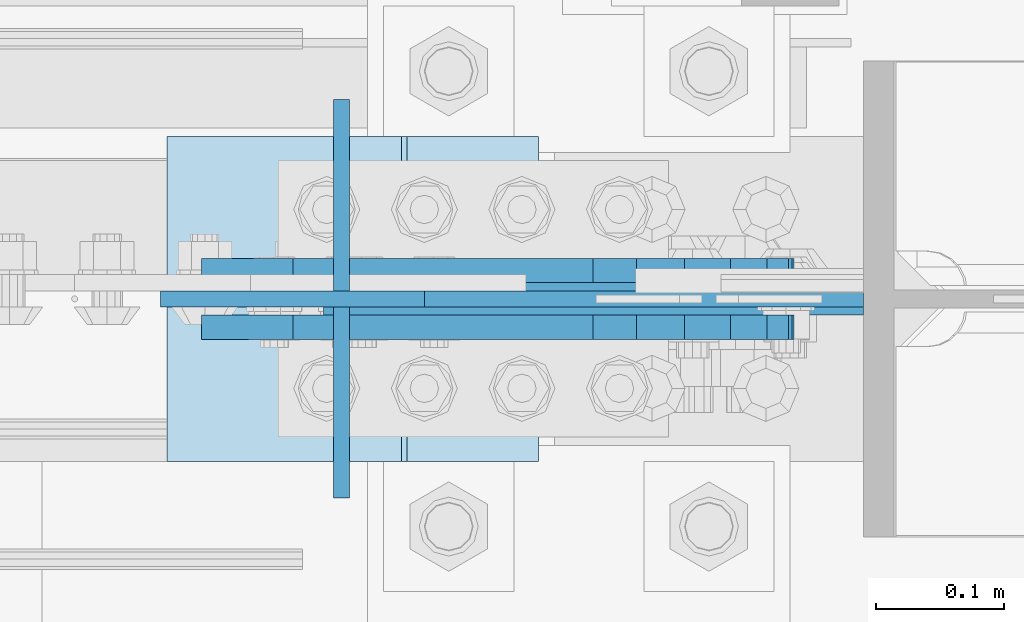
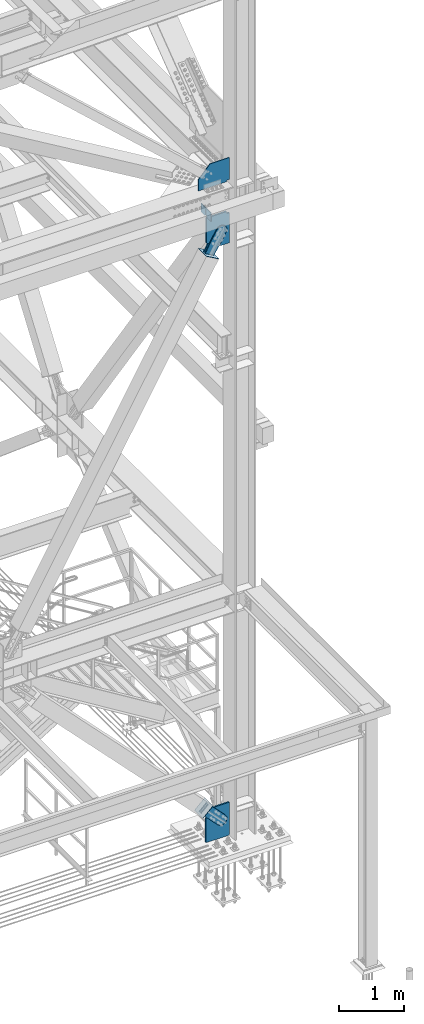
# One storey, part 3560 of 3843: 11 plates, 8 elements without a shape of their own.
"""IFC2X3 building model written with IfcOpenShell, lengths in millimetres."""

from ifc_helpers import new_model, si_unit, frame, origin_with_axes, place, context, subcontext, project, spatial, faceted_brep, material, type_object, element, aggregate, save


model = new_model("IFC2X3")

# Units and contexts
model_context = context("Model", 3, precision=1e-05, world=origin_with_axes())
body_context = subcontext(model_context, "Body", "Model", "MODEL_VIEW")
ifc_project = project(units=[si_unit("LENGTHUNIT", "METRE", prefix="MILLI"), si_unit("AREAUNIT", "SQUARE_METRE"), si_unit("VOLUMEUNIT", "CUBIC_METRE"), si_unit("MASSUNIT", "GRAM", prefix="KILO"), si_unit("TIMEUNIT", "SECOND"), si_unit("PLANEANGLEUNIT", "RADIAN"), si_unit("SOLIDANGLEUNIT", "STERADIAN"), si_unit("THERMODYNAMICTEMPERATUREUNIT", "DEGREE_CELSIUS"), si_unit("LUMINOUSINTENSITYUNIT", "LUMEN")], contexts=[model_context])

# Site, building, storey
site_placement = place(None, origin_with_axes())
site = spatial("IfcSite", under=ifc_project, at=site_placement, CompositionType="ELEMENT")
building_placement = place(site_placement, origin_with_axes())
building = spatial("IfcBuilding", under=site, at=building_placement, Name="Undefined", CompositionType="ELEMENT")
storey_placement = place(building_placement, origin_with_axes())
storey = spatial("IfcBuildingStorey", under=building, at=storey_placement, Name="Undefined", CompositionType="ELEMENT", Elevation=0.0)

# Assembly, plate
assembly_1_placement = place(storey_placement, origin_with_axes())
assembly_1 = element("IfcElementAssembly", 1, at=assembly_1_placement, inside=storey, Name="COLUMN", AssemblyPlace="NOTDEFINED", PredefinedType="RIGID_FRAME")
ifc_material_1 = material(Name="STEEL/A572-50")
plate_type_1 = type_object("IfcPlateType", PredefinedType="NOTDEFINED")
plate_1_placement = place(assembly_1_placement, frame((85464.650000013, 14998.6999998776, 42481.5000000008), z_axis=(0.0, 0.0, 1.0), x_axis=(-1.0, 0.0, 0.0)))
plate_1 = element("IfcPlate", 2, at=plate_1_placement, type_object=plate_type_1, material=ifc_material_1, Name="PLATE", context=body_context, shape_type="Brep", body=[
    faceted_brep([(0.0, -6.35000000000582, 25.3999999992011), (0.0, 6.35000000000582, 25.3999999992011), (38.1000002037326, 6.35000000000582, 25.3999999992011), (38.1000002037326, -6.35000000000582, 25.3999999992011), (42.9600797217718, 6.35000000000582, 24.4332700766099), (42.9600797217718, -6.35000000000582, 24.4332700766099), (47.0802561899327, 6.35000000000582, 21.680256176136), (47.0802561899327, -6.35000000000582, 21.680256176136), (49.8332700904139, 6.35000000000582, 17.5600797079824), (49.8332700904139, -6.35000000000582, 17.5600797079824), (50.8000000129978, -6.35000000000582, 12.700000189936), (50.8000000129978, 6.35000000000582, 12.700000189936), (50.8000000129978, 6.35000000000582, 0.0), (50.8000000129978, -6.35000000000582, 0.0), (0.0, -6.35000000000582, 440.392120302837), (342.865167624404, -6.35000000000582, 440.392120302837), (342.865167624404, 6.35000000000582, 440.392120302837), (0.0, 6.35000000000582, 440.392120302837), (548.874980480497, -6.35000000000582, 215.752415426345), (548.874980480497, 6.35000000000582, 215.752415426345), (548.874980480497, -6.35000000000582, 0.0), (548.874980480497, 6.35000000000582, 0.0)], [[[0, 1, 2, 3]], [[3, 2, 4, 5]], [[5, 4, 6, 7]], [[7, 6, 8, 9]], [[10, 11, 12, 13]], [[9, 8, 11, 10]], [[14, 15, 16, 17]], [[15, 18, 19, 16]], [[18, 20, 21, 19]], [[21, 20, 13, 12]], [[6, 4, 2, 1, 17, 16, 19, 21, 12, 11, 8]], [[14, 17, 1, 0]], [[20, 18, 15, 14, 0, 3, 5, 7, 9, 10, 13]]]),
])

# Assembly, plates
assembly_2_placement = place(storey_placement, origin_with_axes())
assembly_2 = element("IfcElementAssembly", 3, at=assembly_2_placement, inside=storey, Name="BEAM", AssemblyPlace="NOTDEFINED", PredefinedType="RIGID_FRAME")
plate_type_2 = type_object("IfcPlateType", PredefinedType="NOTDEFINED")
plate_2_placement = place(assembly_2_placement, frame((85057.1554852273, 14992.35, 42110.025), z_axis=(0.0, 0.0, -1.0), x_axis=(0.0, -1.0, 0.0)))
plate_2 = element("IfcPlate", 4, at=plate_2_placement, type_object=plate_type_2, material=ifc_material_1, Name="PLATE", context=body_context, shape_type="Brep", body=[
    faceted_brep([(0.0, -6.3499999046162, 0.0), (0.0, -6.35000000000582, 131.762499999997), (0.0, 6.35000000000582, 131.762499999997), (7.27595761418343e-12, 6.3499999046162, 0.0), (31.75, -6.35000000000582, 163.512499999997), (31.75, 6.35000000000582, 163.512499999997), (149.224999999991, -6.35000000000582, 163.512499999997), (149.224999999991, 6.35000000000582, 163.512499999997), (149.224999999991, -6.35000000000582, 0.0), (149.224999999991, 6.35000000000582, 0.0)], [[[0, 1, 2, 3]], [[1, 4, 5, 2]], [[4, 6, 7, 5]], [[6, 8, 9, 7]], [[8, 0, 3, 9]], [[5, 7, 9, 3, 2]], [[8, 6, 4, 1, 0]]]),
])
plate_3_placement = place(assembly_2_placement, frame((85057.1554852273, 15154.275, 42110.025), z_axis=(0.0, 0.0, -1.0), x_axis=(0.0, -1.0, 0.0)))
plate_3 = element("IfcPlate", 5, at=plate_3_placement, type_object=plate_type_2, material=ifc_material_1, Name="PLATE", context=body_context, shape_type="Brep", body=[
    faceted_brep([(0.0, -6.3499999046162, 0.0), (0.0, -6.34999999999854, 163.512499999997), (0.0, 6.34999999999854, 163.512499999997), (7.27595761418343e-12, 6.3499999046162, 0.0), (117.474999999991, -6.34999999999854, 163.512499999997), (117.474999999991, 6.34999999999854, 163.512499999997), (149.224999999991, -6.34999999999854, 131.762499999997), (149.224999999991, 6.34999999999854, 131.762499999997), (149.224999999991, -6.35000000000582, 0.0), (149.224999999991, 6.35000000000582, 0.0)], [[[0, 1, 2, 3]], [[1, 4, 5, 2]], [[4, 6, 7, 5]], [[6, 8, 9, 7]], [[8, 0, 3, 9]], [[5, 7, 9, 3, 2]], [[8, 6, 4, 1, 0]]]),
])
aggregate(assembly_2, [plate_2, plate_3])

# Assembly, plate
assembly_3_placement = place(storey_placement, origin_with_axes())
assembly_3 = element("IfcElementAssembly", 6, at=assembly_3_placement, inside=storey, AssemblyPlace="NOTDEFINED", PredefinedType="RIGID_FRAME")
ifc_material_2 = material(Name="STEEL/A36")
plate_type_3 = type_object("IfcPlateType", PredefinedType="NOTDEFINED")
plate_4_placement = place(assembly_3_placement, frame((85076.9563699565, 15020.925, 30872.9925241429), z_axis=(-0.720244694304652, 0.0, -0.693720102293424), x_axis=(0.693720102293427, 0.0, -0.720244694304649)))
plate_4 = element("IfcPlate", 7, at=plate_4_placement, type_object=plate_type_3, material=ifc_material_2, context=body_context, shape_type="Brep", body=[
    faceted_brep([(0.0, -9.52500000000146, 0.0), (7.37782102078199e-09, -9.52499999999418, 179.651701450231), (7.37782102078199e-09, 9.52499999999418, 179.651701450231), (0.0, 9.52500000000146, 0.0), (69.8500000062704, -9.52499999999418, 179.651701450392), (69.8500000062704, 9.52499999999418, 179.651701450392), (171.449999998309, -9.52499999999418, 186.663350727089), (171.449999998309, 9.52499999999418, 186.663350727089), (434.579297655291, -9.52499999999418, 186.663350728457), (434.579297655291, 9.52499999999418, 186.663350728457), (471.637405120986, -9.52499999999418, 179.292034842016), (471.637405120986, 9.52499999999418, 179.292034842016), (503.05375165752, -9.52499999999418, 158.300303204887), (503.05375165752, 9.52499999999418, 158.300303204887), (524.045483294532, -9.52499999999418, 126.883956668345), (524.045483294532, 9.52499999999418, 126.883956668345), (531.416799180792, -9.52499999999418, 89.8258522538526), (531.416799180792, 9.52499999999418, 89.8258522538526), (524.045483293885, -9.52499999999418, 52.7677447886235), (524.045483293885, 9.52499999999418, 52.7677447886235), (503.053751656611, -9.52499999999418, 21.3513982523873), (503.053751656611, 9.52499999999418, 21.3513982523873), (471.637405120178, -9.52499999999418, 0.359666615346214), (471.637405120178, 9.52499999999418, 0.359666615346214), (434.579299181831, -9.52499999999418, -7.01164927131322), (434.579299181831, 9.52499999999418, -7.01164927131322), (171.449999996272, -9.52499999999418, -7.01164927269565), (171.449999996272, 9.52499999999418, -7.01164927269565), (69.8499999979995, -9.52499999999418, -4.00177668780088e-10), (69.8499999979995, 9.52499999999418, -4.00177668780088e-10)], [[[0, 1, 2, 3]], [[1, 4, 5, 2]], [[4, 6, 7, 5]], [[6, 8, 9, 7]], [[8, 10, 11, 9]], [[10, 12, 13, 11]], [[12, 14, 15, 13]], [[14, 16, 17, 15]], [[16, 18, 19, 17]], [[18, 20, 21, 19]], [[20, 22, 23, 21]], [[22, 24, 25, 23]], [[24, 26, 27, 25]], [[26, 28, 29, 27]], [[28, 0, 3, 29]], [[5, 7, 9, 11, 13, 15, 17, 19, 21, 23, 25, 27, 29, 3, 2]], [[28, 26, 24, 22, 20, 18, 16, 14, 12, 10, 8, 6, 4, 1, 0]]]),
])
aggregate(assembly_3, [plate_4])

assembly_4_placement = place(storey_placement, origin_with_axes())
assembly_4 = element("IfcElementAssembly", 8, at=assembly_4_placement, inside=storey, AssemblyPlace="NOTDEFINED", PredefinedType="RIGID_FRAME")
plate_5_placement = place(assembly_4_placement, frame((85076.9563699565, 14976.475, 30872.9925241429), z_axis=(-0.720244694304652, 0.0, -0.693720102293424), x_axis=(0.693720102293427, 0.0, -0.720244694304649)))
plate_5 = element("IfcPlate", 9, at=plate_5_placement, type_object=plate_type_3, material=ifc_material_2, context=body_context, shape_type="Brep", body=[
    faceted_brep([(0.0, -9.52500000000146, 0.0), (7.37782102078199e-09, -9.52499999999418, 179.651701450231), (7.37782102078199e-09, 9.52499999999418, 179.651701450231), (0.0, 9.52500000000146, 0.0), (69.8500000062704, -9.52499999999418, 179.651701450392), (69.8500000062704, 9.52499999999418, 179.651701450392), (171.449999998309, -9.52499999999418, 186.663350727089), (171.449999998309, 9.52499999999418, 186.663350727089), (434.579297655291, -9.52499999999418, 186.663350728457), (434.579297655291, 9.52499999999418, 186.663350728457), (471.637405120986, -9.52499999999418, 179.292034842016), (471.637405120986, 9.52499999999418, 179.292034842016), (503.05375165752, -9.52499999999418, 158.300303204887), (503.05375165752, 9.52499999999418, 158.300303204887), (524.045483294532, -9.52499999999418, 126.883956668345), (524.045483294532, 9.52499999999418, 126.883956668345), (531.416799180792, -9.52499999999418, 89.8258522538526), (531.416799180792, 9.52499999999418, 89.8258522538526), (524.045483293885, -9.52499999999418, 52.7677447886235), (524.045483293885, 9.52499999999418, 52.7677447886235), (503.053751656611, -9.52499999999418, 21.3513982523873), (503.053751656611, 9.52499999999418, 21.3513982523873), (471.637405120178, -9.52499999999418, 0.359666615346214), (471.637405120178, 9.52499999999418, 0.359666615346214), (434.579299181831, -9.52499999999418, -7.01164927131322), (434.579299181831, 9.52499999999418, -7.01164927131322), (171.449999996272, -9.52499999999418, -7.01164927269565), (171.449999996272, 9.52499999999418, -7.01164927269565), (69.8499999979995, -9.52499999999418, -4.00177668780088e-10), (69.8499999979995, 9.52499999999418, -4.00177668780088e-10)], [[[0, 1, 2, 3]], [[1, 4, 5, 2]], [[4, 6, 7, 5]], [[6, 8, 9, 7]], [[8, 10, 11, 9]], [[10, 12, 13, 11]], [[12, 14, 15, 13]], [[14, 16, 17, 15]], [[16, 18, 19, 17]], [[18, 20, 21, 19]], [[20, 22, 23, 21]], [[22, 24, 25, 23]], [[24, 26, 27, 25]], [[26, 28, 29, 27]], [[28, 0, 3, 29]], [[5, 7, 9, 11, 13, 15, 17, 19, 21, 23, 25, 27, 29, 3, 2]], [[28, 26, 24, 22, 20, 18, 16, 14, 12, 10, 8, 6, 4, 1, 0]]]),
])
aggregate(assembly_4, [plate_5])

assembly_5_placement = place(storey_placement, origin_with_axes())
assembly_5 = element("IfcElementAssembly", 10, at=assembly_5_placement, inside=storey, AssemblyPlace="NOTDEFINED", PredefinedType="RIGID_FRAME")
plate_6_placement = place(assembly_5_placement, frame((85175.3798783938, 15020.925, 41186.7888602026), z_axis=(-0.868467373134178, 0.0, 0.495746328076589), x_axis=(0.495746328076604, 0.0, 0.868467373134169)))
plate_6 = element("IfcPlate", 11, at=plate_6_placement, type_object=plate_type_3, material=ifc_material_2, context=body_context, shape_type="Brep", body=[
    faceted_brep([(0.0, -9.52500000000146, 0.0), (7.37782102078199e-09, -9.52499999999418, 179.651701450231), (7.37782102078199e-09, 9.52499999999418, 179.651701450231), (0.0, 9.52500000000146, 0.0), (69.8500000062704, -9.52499999999418, 179.651701450392), (69.8500000062704, 9.52499999999418, 179.651701450392), (171.449999998309, -9.52499999999418, 186.663350727089), (171.449999998309, 9.52499999999418, 186.663350727089), (434.579297655291, -9.52499999999418, 186.663350728457), (434.579297655291, 9.52499999999418, 186.663350728457), (471.637405120986, -9.52499999999418, 179.292034842016), (471.637405120986, 9.52499999999418, 179.292034842016), (503.05375165752, -9.52499999999418, 158.300303204887), (503.05375165752, 9.52499999999418, 158.300303204887), (524.045483294532, -9.52499999999418, 126.883956668345), (524.045483294532, 9.52499999999418, 126.883956668345), (531.416799180792, -9.52499999999418, 89.8258522538526), (531.416799180792, 9.52499999999418, 89.8258522538526), (524.045483293885, -9.52499999999418, 52.7677447886235), (524.045483293885, 9.52499999999418, 52.7677447886235), (503.053751656611, -9.52499999999418, 21.3513982523873), (503.053751656611, 9.52499999999418, 21.3513982523873), (471.637405120178, -9.52499999999418, 0.359666615346214), (471.637405120178, 9.52499999999418, 0.359666615346214), (434.579299181831, -9.52499999999418, -7.01164927131322), (434.579299181831, 9.52499999999418, -7.01164927131322), (171.449999996272, -9.52499999999418, -7.01164927269565), (171.449999996272, 9.52499999999418, -7.01164927269565), (69.8499999979995, -9.52499999999418, -4.00177668780088e-10), (69.8499999979995, 9.52499999999418, -4.00177668780088e-10)], [[[0, 1, 2, 3]], [[1, 4, 5, 2]], [[4, 6, 7, 5]], [[6, 8, 9, 7]], [[8, 10, 11, 9]], [[10, 12, 13, 11]], [[12, 14, 15, 13]], [[14, 16, 17, 15]], [[16, 18, 19, 17]], [[18, 20, 21, 19]], [[20, 22, 23, 21]], [[22, 24, 25, 23]], [[24, 26, 27, 25]], [[26, 28, 29, 27]], [[28, 0, 3, 29]], [[5, 7, 9, 11, 13, 15, 17, 19, 21, 23, 25, 27, 29, 3, 2]], [[28, 26, 24, 22, 20, 18, 16, 14, 12, 10, 8, 6, 4, 1, 0]]]),
])
aggregate(assembly_5, [plate_6])

assembly_6_placement = place(storey_placement, origin_with_axes())
assembly_6 = element("IfcElementAssembly", 12, at=assembly_6_placement, inside=storey, AssemblyPlace="NOTDEFINED", PredefinedType="RIGID_FRAME")
plate_7_placement = place(assembly_6_placement, frame((85175.3798783938, 14976.475, 41186.7888602026), z_axis=(-0.868467373134178, 0.0, 0.495746328076589), x_axis=(0.495746328076604, 0.0, 0.868467373134169)))
plate_7 = element("IfcPlate", 13, at=plate_7_placement, type_object=plate_type_3, material=ifc_material_2, context=body_context, shape_type="Brep", body=[
    faceted_brep([(0.0, -9.52500000000146, 0.0), (7.37782102078199e-09, -9.52499999999418, 179.651701450231), (7.37782102078199e-09, 9.52499999999418, 179.651701450231), (0.0, 9.52500000000146, 0.0), (69.8500000062704, -9.52499999999418, 179.651701450392), (69.8500000062704, 9.52499999999418, 179.651701450392), (171.449999998309, -9.52499999999418, 186.663350727089), (171.449999998309, 9.52499999999418, 186.663350727089), (434.579297655291, -9.52499999999418, 186.663350728457), (434.579297655291, 9.52499999999418, 186.663350728457), (471.637405120986, -9.52499999999418, 179.292034842016), (471.637405120986, 9.52499999999418, 179.292034842016), (503.05375165752, -9.52499999999418, 158.300303204887), (503.05375165752, 9.52499999999418, 158.300303204887), (524.045483294532, -9.52499999999418, 126.883956668345), (524.045483294532, 9.52499999999418, 126.883956668345), (531.416799180792, -9.52499999999418, 89.8258522538526), (531.416799180792, 9.52499999999418, 89.8258522538526), (524.045483293885, -9.52499999999418, 52.7677447886235), (524.045483293885, 9.52499999999418, 52.7677447886235), (503.053751656611, -9.52499999999418, 21.3513982523873), (503.053751656611, 9.52499999999418, 21.3513982523873), (471.637405120178, -9.52499999999418, 0.359666615346214), (471.637405120178, 9.52499999999418, 0.359666615346214), (434.579299181831, -9.52499999999418, -7.01164927131322), (434.579299181831, 9.52499999999418, -7.01164927131322), (171.449999996272, -9.52499999999418, -7.01164927269565), (171.449999996272, 9.52499999999418, -7.01164927269565), (69.8499999979995, -9.52499999999418, -4.00177668780088e-10), (69.8499999979995, 9.52499999999418, -4.00177668780088e-10)], [[[0, 1, 2, 3]], [[1, 4, 5, 2]], [[4, 6, 7, 5]], [[6, 8, 9, 7]], [[8, 10, 11, 9]], [[10, 12, 13, 11]], [[12, 14, 15, 13]], [[14, 16, 17, 15]], [[16, 18, 19, 17]], [[18, 20, 21, 19]], [[20, 22, 23, 21]], [[22, 24, 25, 23]], [[24, 26, 27, 25]], [[26, 28, 29, 27]], [[28, 0, 3, 29]], [[5, 7, 9, 11, 13, 15, 17, 19, 21, 23, 25, 27, 29, 3, 2]], [[28, 26, 24, 22, 20, 18, 16, 14, 12, 10, 8, 6, 4, 1, 0]]]),
])
aggregate(assembly_6, [plate_7])

assembly_7_placement = place(storey_placement, origin_with_axes())
assembly_7 = element("IfcElementAssembly", 14, at=assembly_7_placement, inside=storey, Name="Plate", AssemblyPlace="NOTDEFINED", PredefinedType="RIGID_FRAME")
plate_type_4 = type_object("IfcPlateType", PredefinedType="NOTDEFINED")
plate_8_placement = place(assembly_7_placement, frame((84922.9912627079, 15125.7, 30720.2892959), z_axis=(0.720244694304641, 0.0, 0.693720102293435), x_axis=(0.0, -1.0, 0.0)))
plate_8 = element("IfcPlate", 15, at=plate_8_placement, type_object=plate_type_4, material=ifc_material_2, Name="Plate", context=body_context, shape_type="Brep", body=[
    faceted_brep([(0.0, -3.17499999999927, 0.0), (0.0, -3.17499999965185, 254.000000005151), (0.0, 3.17500000035216, 254.000000005166), (0.0, 3.17499999999927, 0.0), (254.0, -3.17499999965185, 254.000000005151), (254.0, 3.17500000035216, 254.000000005166), (254.0, -3.17500000000291, 0.0), (254.0, 3.17499999999927, 1.45519152283669e-11)], [[[0, 1, 2, 3]], [[1, 4, 5, 2]], [[4, 6, 7, 5]], [[6, 0, 3, 7]], [[5, 7, 3, 2]], [[6, 4, 1, 0]]]),
])
aggregate(assembly_7, [plate_8])

assembly_8_placement = place(storey_placement, origin_with_axes())
assembly_8 = element("IfcElementAssembly", 16, at=assembly_8_placement, inside=storey, Name="Plate", AssemblyPlace="NOTDEFINED", PredefinedType="RIGID_FRAME")
plate_9_placement = place(assembly_8_placement, frame((85209.2384089813, 14871.7, 41171.1172960143), z_axis=(-0.868467373134178, 0.0, 0.495746328076589), x_axis=(0.0, 1.0, 0.0)))
plate_9 = element("IfcPlate", 17, at=plate_9_placement, type_object=plate_type_4, material=ifc_material_2, Name="Plate", context=body_context, shape_type="Brep", body=[
    faceted_brep([(0.0, -3.17499999999927, 0.0), (0.0, -3.17499999965185, 254.000000005151), (0.0, 3.17500000035216, 254.000000005166), (0.0, 3.17499999999927, 0.0), (254.0, -3.17499999965185, 254.000000005151), (254.0, 3.17500000035216, 254.000000005166), (254.0, -3.17500000000291, 0.0), (254.0, 3.17499999999927, 1.45519152283669e-11)], [[[0, 1, 2, 3]], [[1, 4, 5, 2]], [[4, 6, 7, 5]], [[6, 0, 3, 7]], [[5, 7, 3, 2]], [[6, 4, 1, 0]]]),
])
aggregate(assembly_8, [plate_9])

# Plate
plate_type_5 = type_object("IfcPlateType", PredefinedType="NOTDEFINED")
plate_10_placement = place(assembly_1_placement, frame((85464.65, 14998.7, 30149.8), z_axis=(0.0, 0.0, 1.0), x_axis=(-1.0, 0.0, 0.0)))
plate_10 = element("IfcPlate", 18, at=plate_10_placement, type_object=plate_type_5, material=ifc_material_1, Name="CB", context=body_context, shape_type="Brep", body=[
    faceted_brep([(0.0, -12.6999999999971, 19.0499992370605), (0.0, -12.7000000000007, 622.191183947351), (0.0, 12.7000000000007, 622.191183947351), (0.0, 12.6999999999971, 19.0499992370605), (245.411000082924, -12.7000000000007, 622.191183947351), (245.411000082924, 12.7000000000007, 622.191183947351), (421.492821723063, -12.7000000000007, 452.593961939165), (421.492821723063, 12.7000000000007, 452.593961939165), (421.492821723063, -12.7000000000007, 0.0), (421.492821723063, 12.7000000000007, 0.0), (19.0500015258731, -12.6999999999971, -6.33008312433958e-10), (19.0500015258731, 12.6999999999971, 0.0)], [[[0, 1, 2, 3]], [[1, 4, 5, 2]], [[4, 6, 7, 5]], [[6, 8, 9, 7]], [[8, 10, 11, 9]], [[10, 0, 3, 11]], [[5, 7, 9, 11, 3, 2]], [[10, 8, 6, 4, 1, 0]]]),
])

plate_type_6 = type_object("IfcPlateType", PredefinedType="NOTDEFINED")
plate_11_placement = place(assembly_1_placement, frame((85050.8054852272, 14998.7, 42468.8), z_axis=(0.0, 0.0, -1.0), x_axis=(1.0, 0.0, 0.0)))
plate_11 = element("IfcPlate", 19, at=plate_11_placement, type_object=plate_type_6, material=ifc_material_1, Name="CB", context=body_context, shape_type="Brep", body=[
    faceted_brep([(363.044514772759, -12.7000000000007, 542.925000000003), (363.044514772759, 12.7000000000007, 542.925000000003), (363.044514772759, 12.7000000000007, 568.240182560687), (363.044514772759, -12.7000000000007, 568.240182560687), (364.011244695343, 12.7000000000007, 573.100262078733), (364.011244695343, -12.7000000000007, 573.100262078733), (366.764258595824, 12.7000000000007, 577.220438546887), (366.764258595824, -12.7000000000007, 577.220438546887), (370.884435063985, 12.7000000000007, 579.973452447361), (370.884435063985, -12.7000000000007, 579.973452447361), (375.744514582024, 12.7000000000007, 580.940182369952), (375.744514582024, -12.7000000000007, 580.940182369952), (413.844514772747, -12.7000000000007, 580.940182369952), (413.844514772747, 12.7000000000007, 580.940182369952), (0.0, -12.7000000000007, 1013.4837255796), (0.0, 12.7000000000007, 1013.4837255796), (0.0, 12.7000000000007, 542.925000000003), (0.0, -12.7000000000007, 542.925000000003), (237.718561046975, -12.7000000000007, 1149.18036473991), (237.718561046975, 12.7000000000007, 1149.18036473991), (413.844514772747, -12.7000000000007, 1149.18036473991), (413.844514772747, 12.7000000000007, 1149.18036473991)], [[[0, 1, 2, 3]], [[3, 2, 4, 5]], [[5, 4, 6, 7]], [[7, 6, 8, 9]], [[9, 8, 10, 11]], [[12, 11, 10, 13]], [[14, 15, 16, 17]], [[14, 18, 19, 15]], [[18, 20, 21, 19]], [[21, 20, 12, 13]], [[8, 6, 4, 2, 1, 16, 15, 19, 21, 13, 10]], [[17, 16, 1, 0]], [[20, 18, 14, 17, 0, 3, 5, 7, 9, 11, 12]]]),
])

aggregate(assembly_1, [plate_10, plate_11, plate_1])

save(model, "model.ifc")
